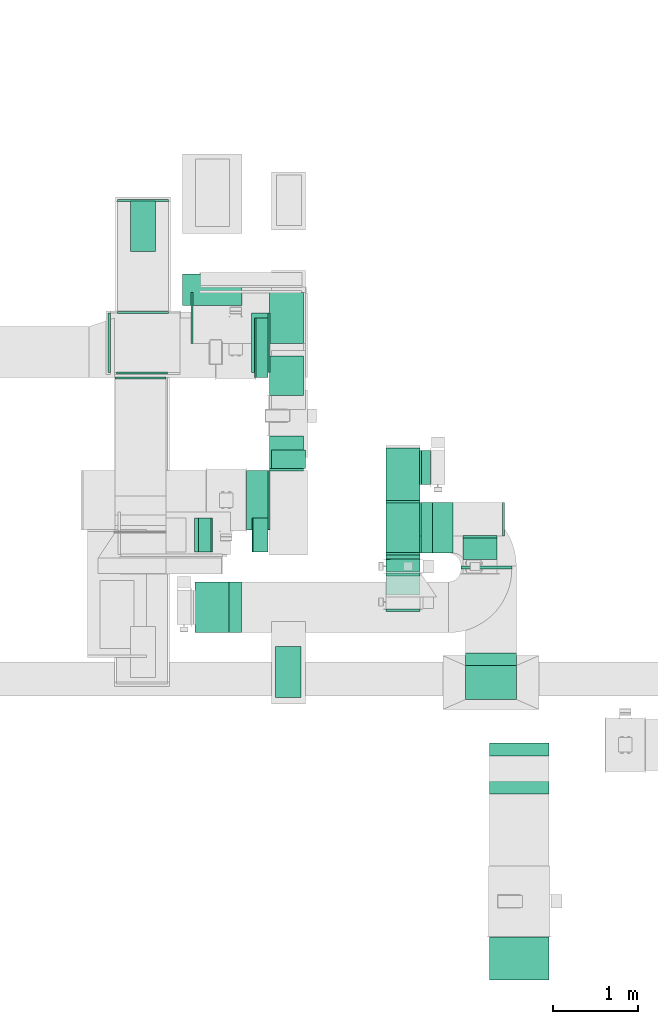
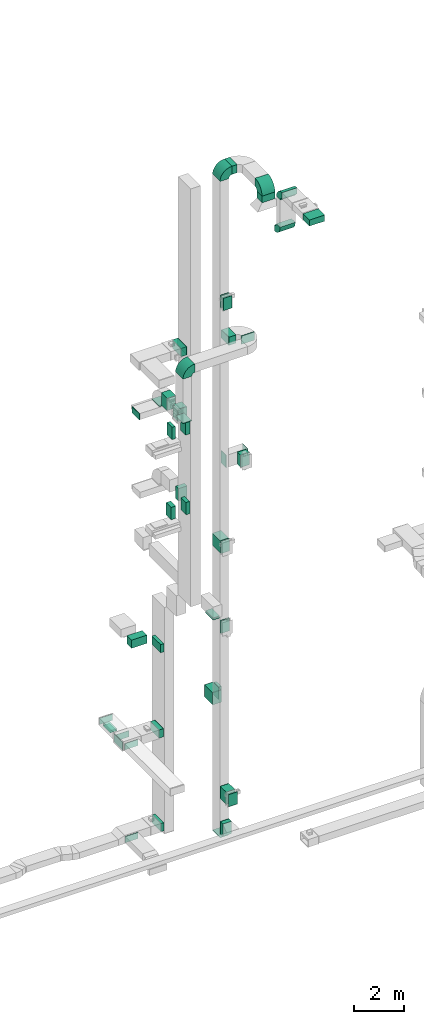
# One storey, part 12 of 25: 32 flow fittings, 28 flow segments, 1 flow terminal.
"""IFC2X3 building model written with IfcOpenShell, lengths in millimetres."""

from ifc_helpers import new_model, entity, si_unit, converted_unit, derived_unit, direction, frame, frame_2d, origin, origin_2d_with_axis, place, context, subcontext, project, spatial, polyline, circle_curve, parameter, trimmed, segment, composite_curve, rectangle, outline, extrude, source, transform, mapped, material, type_object, type_shapes, element, save


model = new_model("IFC2X3")

# Units and contexts
model_context = context("Model", 3, precision=0.01, world=origin(), true_north=direction((6.12303176911189e-17, 1.0)))
body_context = subcontext(model_context, "Body", "Model", "MODEL_VIEW")
ifc_project = project(units=[si_unit("LENGTHUNIT", "METRE", prefix="MILLI"), si_unit("AREAUNIT", "SQUARE_METRE"), si_unit("VOLUMEUNIT", "CUBIC_METRE"), converted_unit("PLANEANGLEUNIT", "DEGREE", entity("IfcRatioMeasure", 0.0174532925199433), si_unit("PLANEANGLEUNIT", "RADIAN"), dimensions=[0, 0, 0, 0, 0, 0, 0]), si_unit("MASSUNIT", "GRAM", prefix="KILO"), derived_unit("MASSDENSITYUNIT", [(si_unit("MASSUNIT", "GRAM", prefix="KILO"), 1), (si_unit("LENGTHUNIT", "METRE"), -3)]), derived_unit("MOMENTOFINERTIAUNIT", [(si_unit("LENGTHUNIT", "METRE"), 4)]), si_unit("TIMEUNIT", "SECOND"), si_unit("FREQUENCYUNIT", "HERTZ"), si_unit("THERMODYNAMICTEMPERATUREUNIT", "DEGREE_CELSIUS"), derived_unit("THERMALTRANSMITTANCEUNIT", [(si_unit("MASSUNIT", "GRAM", prefix="KILO"), 1), (si_unit("THERMODYNAMICTEMPERATUREUNIT", "KELVIN"), -1), (si_unit("TIMEUNIT", "SECOND"), -3)]), derived_unit("VOLUMETRICFLOWRATEUNIT", [(si_unit("LENGTHUNIT", "METRE"), 3), (si_unit("TIMEUNIT", "SECOND"), -1)]), derived_unit("MASSFLOWRATEUNIT", [(si_unit("MASSUNIT", "GRAM", prefix="KILO"), 1), (si_unit("TIMEUNIT", "SECOND"), -1)]), derived_unit("ROTATIONALFREQUENCYUNIT", [(si_unit("TIMEUNIT", "SECOND"), -1)]), si_unit("ELECTRICCURRENTUNIT", "AMPERE"), si_unit("ELECTRICVOLTAGEUNIT", "VOLT"), si_unit("POWERUNIT", "WATT"), si_unit("FORCEUNIT", "NEWTON", prefix="KILO"), si_unit("ILLUMINANCEUNIT", "LUX"), si_unit("LUMINOUSFLUXUNIT", "LUMEN"), si_unit("LUMINOUSINTENSITYUNIT", "CANDELA"), derived_unit("USERDEFINED", [(si_unit("MASSUNIT", "GRAM", prefix="KILO"), -1), (si_unit("LENGTHUNIT", "METRE"), -2), (si_unit("TIMEUNIT", "SECOND"), 3), (si_unit("LUMINOUSFLUXUNIT", "LUMEN"), 1)]), derived_unit("LINEARVELOCITYUNIT", [(si_unit("LENGTHUNIT", "METRE"), 1), (si_unit("TIMEUNIT", "SECOND"), -1)]), si_unit("PRESSUREUNIT", "PASCAL"), derived_unit("USERDEFINED", [(si_unit("LENGTHUNIT", "METRE"), -2), (si_unit("MASSUNIT", "GRAM", prefix="KILO"), 1), (si_unit("TIMEUNIT", "SECOND"), -2)]), derived_unit("LINEARFORCEUNIT", [(si_unit("MASSUNIT", "GRAM", prefix="KILO"), 1), (si_unit("LENGTHUNIT", "METRE"), 1), (si_unit("TIMEUNIT", "SECOND"), -2), (si_unit("LENGTHUNIT", "METRE"), -1)]), derived_unit("PLANARFORCEUNIT", [(si_unit("MASSUNIT", "GRAM", prefix="KILO"), 1), (si_unit("LENGTHUNIT", "METRE"), 1), (si_unit("TIMEUNIT", "SECOND"), -2), (si_unit("LENGTHUNIT", "METRE"), -2)])], contexts=[model_context])

# Site, building, storey
site_placement = place(None, origin())
site = spatial("IfcSite", under=ifc_project, at=site_placement, CompositionType="ELEMENT")
building_placement = place(site_placement, origin())
building = spatial("IfcBuilding", under=site, at=building_placement, CompositionType="ELEMENT")
storey_placement = place(building_placement, origin())
storey = spatial("IfcBuildingStorey", under=building, at=storey_placement, CompositionType="ELEMENT", Elevation=0.0)

# Flow segments
duct_segment_type = type_object("IfcDuctSegmentType", PredefinedType="NOTDEFINED")
flow_segment_1_placement = place(storey_placement, frame((30023.91, 10939.62, 22300.0)))
element("IfcFlowSegment", 1, at=flow_segment_1_placement, inside=storey, type_object=duct_segment_type, context=body_context, shape_type="SweptSolid", body=[
    extrude(rectangle(XDim=251.096000000203, YDim=699.999999999999, at=origin_2d_with_axis()), frame((125.55, 350.0, 0.0)), (0.0, 0.0, 1.0), 399.999999999996),
])
flow_segment_2_placement = place(storey_placement, frame((29456.92, 10677.38, 18600.0)))
element("IfcFlowSegment", 2, at=flow_segment_2_placement, inside=storey, type_object=duct_segment_type, context=body_context, shape_type="SweptSolid", body=[
    extrude(rectangle(XDim=150.000000000005, YDim=400.0, at=origin_2d_with_axis()), frame((75.0, 200.0, 0.0), z_axis=(0.0, 0.0, 1.0), x_axis=(-1.0, 0.0, 0.0)), (0.0, 0.0, 1.0), 599.999999999998),
])
flow_segment_3_placement = place(storey_placement, frame((30086.92, 10677.38, 18600.0)))
element("IfcFlowSegment", 3, at=flow_segment_3_placement, inside=storey, type_object=duct_segment_type, context=body_context, shape_type="SweptSolid", body=[
    extrude(rectangle(XDim=188.084749285835, YDim=400.0, at=origin_2d_with_axis()), frame((94.04, 200.0, 0.0), z_axis=(0.0, 0.0, 1.0), x_axis=(-1.0, 0.0, 0.0)), (0.0, 0.0, 1.0), 600.000000000002),
])
flow_segment_4_placement = place(storey_placement, frame((30101.92, 10677.38, 14700.0)))
element("IfcFlowSegment", 4, at=flow_segment_4_placement, inside=storey, type_object=duct_segment_type, context=body_context, shape_type="SweptSolid", body=[
    extrude(rectangle(XDim=173.084749285813, YDim=400.0, at=origin_2d_with_axis()), frame((86.54, 200.0, 0.0), z_axis=(0.0, 0.0, 1.0), x_axis=(-1.0, 0.0, 0.0)), (0.0, 0.0, 1.0), 600.000000000002),
])
flow_segment_5_placement = place(storey_placement, frame((30365.0, 8960.33, 10500.0)))
element("IfcFlowSegment", 5, at=flow_segment_5_placement, inside=storey, type_object=duct_segment_type, context=body_context, shape_type="SweptSolid", body=[
    extrude(rectangle(XDim=300.000000000001, YDim=600.0, at=origin_2d_with_axis()), frame((150.0, 300.0, 0.0)), (0.0, 0.0, 1.0), 79.9999999999688),
])
flow_segment_6_placement = place(storey_placement, frame((30120.05, 12737.72, 6700.0)))
element("IfcFlowSegment", 6, at=flow_segment_6_placement, inside=storey, type_object=duct_segment_type, context=body_context, shape_type="SweptSolid", body=[
    extrude(rectangle(XDim=154.950539610895, YDim=699.999999999999, at=origin_2d_with_axis()), frame((77.48, 350.0, 0.0), z_axis=(0.0, 0.0, 1.0), x_axis=(-1.0, 0.0, 0.0)), (0.0, 0.0, 1.0), 400.0),
])
flow_segment_7_placement = place(storey_placement, frame((30320.0, 11661.58, 14700.0)))
element("IfcFlowSegment", 7, at=flow_segment_7_placement, inside=storey, type_object=duct_segment_type, context=body_context, shape_type="SweptSolid", body=[
    extrude(rectangle(XDim=221.175631375204, YDim=400.0, at=origin_2d_with_axis()), frame((200.0, 110.59, 0.0), z_axis=(0.0, 0.0, 1.0), x_axis=(0.0, 1.0, 0.0)), (0.0, 0.0, 1.0), 600.000000000002),
])
flow_segment_8_placement = place(storey_placement, frame((30295.0, 11661.84, 18600.0)))
element("IfcFlowSegment", 8, at=flow_segment_8_placement, inside=storey, type_object=duct_segment_type, context=body_context, shape_type="SweptSolid", body=[
    extrude(rectangle(XDim=384.504473210767, YDim=400.0, at=origin_2d_with_axis()), frame((200.0, 192.25, 0.0), z_axis=(0.0, 0.0, 1.0), x_axis=(0.0, -1.0, 0.0)), (0.0, 0.0, 1.0), 600.000000000002),
])
flow_segment_9_placement = place(storey_placement, frame((29270.05, 13587.72, 6700.0)))
element("IfcFlowSegment", 9, at=flow_segment_9_placement, inside=storey, type_object=duct_segment_type, context=body_context, shape_type="SweptSolid", body=[
    extrude(rectangle(XDim=371.982987517842, YDim=700.000000000001, at=origin_2d_with_axis()), frame((350.0, 185.99, 0.0), z_axis=(0.0, 0.0, 1.0), x_axis=(0.0, 1.0, 0.0)), (0.0, 0.0, 1.0), 400.0),
])
flow_segment_10_placement = place(storey_placement, frame((28651.05, 14225.01, 2400.0)))
element("IfcFlowSegment", 10, at=flow_segment_10_placement, inside=storey, type_object=duct_segment_type, context=body_context, shape_type="SweptSolid", body=[
    extrude(rectangle(XDim=599.999999999998, YDim=300.000000000001, at=origin_2d_with_axis()), frame((150.0, 300.0, 0.0), z_axis=(0.0, 0.0, 1.0), x_axis=(0.0, 1.0, 0.0)), (0.0, 0.0, 1.0), 79.9999999999699),
])
flow_segment_11_placement = place(storey_placement, frame((30080.11, 12797.72, 2500.0)))
element("IfcFlowSegment", 11, at=flow_segment_11_placement, inside=storey, type_object=duct_segment_type, context=body_context, shape_type="SweptSolid", body=[
    extrude(rectangle(XDim=194.892683525825, YDim=699.999999999999, at=origin_2d_with_axis()), frame((97.45, 350.0, 0.0), z_axis=(0.0, 0.0, 1.0), x_axis=(-1.0, 0.0, 0.0)), (0.0, 0.0, 1.0), 400.0),
])
flow_segment_12_placement = place(storey_placement, frame((30135.54, 12739.72, -2050.0)))
element("IfcFlowSegment", 12, at=flow_segment_12_placement, inside=storey, type_object=duct_segment_type, context=body_context, shape_type="SweptSolid", body=[
    extrude(rectangle(XDim=139.457065215677, YDim=699.999999999999, at=origin_2d_with_axis()), frame((69.73, 350.0, 0.0)), (0.0, 0.0, 1.0), 400.0),
])
flow_segment_13_placement = place(storey_placement, frame((32219.87, 10665.1, 30605.49)))
element("IfcFlowSegment", 13, at=flow_segment_13_placement, inside=storey, type_object=duct_segment_type, context=body_context, shape_type="SweptSolid", body=[
    extrude(rectangle(XDim=239.145151963278, YDim=600.0, at=origin_2d_with_axis()), frame((119.57, 300.0, 0.0)), (0.0, 0.0, 1.0), 399.999999999996),
])
flow_segment_14_placement = place(storey_placement, frame((31669.87, 10592.36, 24300.0)))
element("IfcFlowSegment", 14, at=flow_segment_14_placement, inside=storey, type_object=duct_segment_type, context=body_context, shape_type="SweptSolid", body=[
    extrude(rectangle(XDim=52.6715277765037, YDim=400.000000000002, at=origin_2d_with_axis()), frame((200.01, 26.4, 0.0), z_axis=(0.0, 0.0, 1.0), x_axis=(0.000311966680507818, -0.999999951338394, 0.0)), (0.0, 0.0, 1.0), 600.000000000002),
])
flow_segment_15_placement = place(storey_placement, frame((32089.87, 10665.1, 22300.0)))
element("IfcFlowSegment", 15, at=flow_segment_15_placement, inside=storey, type_object=duct_segment_type, context=body_context, shape_type="SweptSolid", body=[
    extrude(rectangle(XDim=315.331551336668, YDim=600.0, at=origin_2d_with_axis()), frame((157.67, 300.0, 0.0), z_axis=(0.0, 0.0, 1.0), x_axis=(-1.0, 0.0, 0.0)), (0.0, 0.0, 1.0), 399.999999999996),
])
flow_segment_16_placement = place(storey_placement, frame((32555.21, 10474.94, 22300.0)))
element("IfcFlowSegment", 16, at=flow_segment_16_placement, inside=storey, type_object=duct_segment_type, context=body_context, shape_type="SweptSolid", body=[
    extrude(rectangle(XDim=40.1525169212813, YDim=600.000000000002, at=origin_2d_with_axis()), frame((300.0, 20.08, 0.0), z_axis=(0.0, 0.0, 1.0), x_axis=(0.0, 1.0, 0.0)), (0.0, 0.0, 1.0), 399.999999999996),
])
flow_segment_17_placement = place(storey_placement, frame((32581.61, 10592.04, 16200.0)))
element("IfcFlowSegment", 17, at=flow_segment_17_placement, inside=storey, type_object=duct_segment_type, context=body_context, shape_type="SweptSolid", body=[
    extrude(rectangle(XDim=253.039939388961, YDim=399.999999999998, at=origin_2d_with_axis()), frame((200.01, 126.53, 0.0), z_axis=(0.0, 0.0, 1.0), x_axis=(6.49374233861676e-05, -0.999999997891566, 0.0)), (0.0, 0.0, 1.0), 599.999999999998),
])
flow_segment_18_placement = place(storey_placement, frame((31669.88, 10594.95, 12300.0)))
element("IfcFlowSegment", 18, at=flow_segment_18_placement, inside=storey, type_object=duct_segment_type, context=body_context, shape_type="SweptSolid", body=[
    extrude(rectangle(XDim=50.0956791701616, YDim=400.000000000001, at=origin_2d_with_axis()), frame((200.01, 25.09, 0.0), z_axis=(0.0, 0.0, 1.0), x_axis=(0.000234419037960343, -0.999999972523857, 0.0)), (0.0, 0.0, 1.0), 599.999999999998),
])
flow_segment_19_placement = place(storey_placement, frame((31669.87, 11285.1, 4500.0)))
element("IfcFlowSegment", 19, at=flow_segment_19_placement, inside=storey, type_object=duct_segment_type, context=body_context, shape_type="SweptSolid", body=[
    extrude(rectangle(XDim=623.157125447534, YDim=400.0, at=origin_2d_with_axis()), frame((200.0, 311.58, 0.0), z_axis=(0.0, 0.0, 1.0), x_axis=(0.0, 1.0, 0.0)), (0.0, 0.0, 1.0), 600.0),
])
flow_segment_20_placement = place(storey_placement, frame((32089.84, 11475.22, 4500.0)))
element("IfcFlowSegment", 20, at=flow_segment_20_placement, inside=storey, type_object=duct_segment_type, context=body_context, shape_type="SweptSolid", body=[
    extrude(rectangle(XDim=108.106004089515, YDim=400.0, at=origin_2d_with_axis()), frame((54.08, 200.01, 0.0), z_axis=(0.0, 0.0, 1.0), x_axis=(0.999999988448493, 0.00015199675370579, 0.0)), (0.0, 0.0, 1.0), 600.000000000001),
])
flow_segment_21_placement = place(storey_placement, frame((31669.87, 10172.23, 300.0)))
element("IfcFlowSegment", 21, at=flow_segment_21_placement, inside=storey, type_object=duct_segment_type, context=body_context, shape_type="SweptSolid", body=[
    extrude(rectangle(XDim=471.797025863042, YDim=400.000000000001, at=origin_2d_with_axis()), frame((200.01, 235.91, 0.0), z_axis=(0.0, 0.0, 1.0), x_axis=(3.48280314986155e-05, -1.0, 0.0)), (0.0, 0.0, 1.0), 600.0),
])
flow_segment_22_placement = place(storey_placement, frame((31669.87, 10445.0, -1425.0)))
element("IfcFlowSegment", 22, at=flow_segment_22_placement, inside=storey, type_object=duct_segment_type, context=body_context, shape_type="SweptSolid", body=[
    extrude(rectangle(XDim=200.095053159419, YDim=400.0, at=origin_2d_with_axis()), frame((200.0, 100.05, 0.0), z_axis=(0.0, 0.0, 1.0), x_axis=(0.0, 1.0, 0.0)), (0.0, 0.0, 1.0), 600.0),
])
flow_segment_23_placement = place(storey_placement, frame((32894.02, 5625.0, 30900.0)))
element("IfcFlowSegment", 23, at=flow_segment_23_placement, inside=storey, type_object=duct_segment_type, context=body_context, shape_type="SweptSolid", body=[
    extrude(rectangle(XDim=507.958451099597, YDim=700.000000000001, at=origin_2d_with_axis()), frame((350.0, 253.98, 0.0), z_axis=(0.0, 0.0, 1.0), x_axis=(0.0, -1.0, 0.0)), (0.0, 0.0, 1.0), 300.000000000001),
])
flow_segment_24_placement = place(storey_placement, frame((32609.02, 8936.91, 30130.0)))
element("IfcFlowSegment", 24, at=flow_segment_24_placement, inside=storey, type_object=duct_segment_type, context=body_context, shape_type="SweptSolid", body=[
    extrude(rectangle(XDim=600.000000000002, YDim=400.0, at=origin_2d_with_axis()), frame((300.0, 200.0, 0.0)), (0.0, 0.0, 1.0), 325.490894035817),
])
flow_segment_25_placement = place(storey_placement, frame((31669.88, 10595.33, 8400.0)))
element("IfcFlowSegment", 25, at=flow_segment_25_placement, inside=storey, type_object=duct_segment_type, context=body_context, shape_type="SweptSolid", body=[
    extrude(rectangle(XDim=49.715642394297, YDim=400.000000000001, at=origin_2d_with_axis()), frame((200.01, 24.9, 0.0), z_axis=(0.0, 0.0, 1.0), x_axis=(-0.00023569691278059, 0.999999972223482, 0.0)), (0.0, 0.0, 1.0), 600.0),
])
flow_segment_26_placement = place(storey_placement, frame((29411.92, 10677.38, 14700.0)))
element("IfcFlowSegment", 26, at=flow_segment_26_placement, inside=storey, type_object=duct_segment_type, context=body_context, shape_type="SweptSolid", body=[
    extrude(rectangle(XDim=210.000000000009, YDim=400.0, at=origin_2d_with_axis()), frame((105.0, 200.0, 0.0), z_axis=(0.0, 0.0, 1.0), x_axis=(-1.0, 0.0, 0.0)), (0.0, 0.0, 1.0), 600.000000000002),
])
flow_segment_27_placement = place(storey_placement, frame((30295.0, 12526.34, 18600.0)))
element("IfcFlowSegment", 27, at=flow_segment_27_placement, inside=storey, type_object=duct_segment_type, context=body_context, shape_type="SweptSolid", body=[
    extrude(rectangle(XDim=466.041082953118, YDim=400.0, at=origin_2d_with_axis()), frame((200.0, 233.02, 0.0), z_axis=(0.0, 0.0, 1.0), x_axis=(0.0, 1.0, 0.0)), (0.0, 0.0, 1.0), 600.000000000002),
])
flow_segment_28_placement = place(storey_placement, frame((30295.0, 13142.38, 18420.0)))
element("IfcFlowSegment", 28, at=flow_segment_28_placement, inside=storey, type_object=duct_segment_type, context=body_context, shape_type="SweptSolid", body=[
    extrude(rectangle(XDim=400.000000000004, YDim=600.0, at=origin_2d_with_axis()), frame((200.0, 300.0, 0.0)), (0.0, 0.0, 1.0), 29.9999999999975),
])

# Flow fittings
ifc_material_1 = material()
duct_fitting_type_1 = type_object("IfcDuctFittingType", PredefinedType="NOTDEFINED", material=ifc_material_1)
shared_shape_1 = source(origin(), body_context, "Body", "SweptSolid", [
    extrude(rectangle(XDim=24.9999999999999, YDim=700.0, at=origin_2d_with_axis()), frame((12.5, 0.0, -200.0)), (0.0, 0.0, 1.0), 400.0),
])
type_shapes(duct_fitting_type_1, [shared_shape_1])
flow_fitting_1_placement = place(storey_placement, frame((28415.0, 13147.72, 2700.0), z_axis=(0.0, 0.0, 1.0), x_axis=(-1.0, 0.0, 0.0)))
element("IfcFlowFitting", 29, at=flow_fitting_1_placement, inside=storey, type_object=duct_fitting_type_1, material=ifc_material_1, context=body_context, shape_type="MappedRepresentation", body=[
    mapped(shared_shape_1, transform((0.0, 0.0, 0.0), scale=1.0)),
])
duct_fitting_type_2 = type_object("IfcDuctFittingType", PredefinedType="NOTDEFINED", material=ifc_material_1)
shared_shape_2 = source(origin(), body_context, "Body", "SweptSolid", [
    extrude(rectangle(XDim=26.0960000000006, YDim=400.0, at=origin_2d_with_axis()), frame((6.95, 0.0, -350.0)), (0.0, 0.0, 1.0), 700.0),
])
type_shapes(duct_fitting_type_2, [shared_shape_2])
for number, where, z_axis, x_axis in (
    (30, (30295.0, 11292.62, 22500.0), (0.0, 1.0, 0.0), (-1.0, 0.0, 0.0)),
    (31, (30295.0, 13147.72, 2700.0), (0.0, 1.0, 0.0), (-1.0, 0.0, 0.0)),
    (32, (30295.0, 11289.62, 22500.0), (0.0, 1.0, 0.0), (-1.0, 0.0, 0.0)),
):
    element("IfcFlowFitting", number, at=place(storey_placement, frame(where, z_axis=z_axis, x_axis=x_axis)), inside=storey, type_object=duct_fitting_type_2, material=ifc_material_1, context=body_context, shape_type="MappedRepresentation", body=[
        mapped(shared_shape_2, transform((0.0, 0.0, 0.0), scale=1.0)),
    ])
duct_fitting_type_3 = type_object("IfcDuctFittingType", PredefinedType="NOTDEFINED", material=ifc_material_1)
shared_shape_3 = source(origin(), body_context, "Body", "SweptSolid", [
    extrude(rectangle(XDim=26.0960000000009, YDim=600.0, at=origin_2d_with_axis()), frame((6.95, 0.0, -200.0)), (0.0, 0.0, 1.0), 400.0),
])
type_shapes(duct_fitting_type_3, [shared_shape_3])
for number, where, z_axis, x_axis in (
    (33, (31869.87, 10665.1, 24600.0), (-1.0, 0.0, 0.0), (0.0, -1.0, 0.0)),
    (34, (32069.87, 11065.1, 16500.0), (0.0, -1.0, 0.0), (1.0, 0.0, 0.0)),
    (35, (31869.87, 11265.1, 4800.0), (1.0, 0.0, 0.0), (0.0, 1.0, 0.0)),
):
    element("IfcFlowFitting", number, at=place(storey_placement, frame(where, z_axis=z_axis, x_axis=x_axis)), inside=storey, type_object=duct_fitting_type_3, material=ifc_material_1, context=body_context, shape_type="MappedRepresentation", body=[
        mapped(shared_shape_3, transform((0.0, 0.0, 0.0), scale=1.0)),
    ])
duct_fitting_type_4 = type_object("IfcDuctFittingType", PredefinedType="NOTDEFINED", material=ifc_material_1)
shared_shape_4 = source(origin(), body_context, "Body", "SweptSolid", [
    extrude(rectangle(XDim=24.9999999999999, YDim=400.0, at=origin_2d_with_axis()), frame((12.5, 0.0, -300.0)), (0.0, 0.0, 1.0), 600.0),
])
type_shapes(duct_fitting_type_4, [shared_shape_4])
flow_fitting_2_placement = place(storey_placement, frame((31869.87, 10422.42, 24600.0), z_axis=(0.0, 0.0, 1.0), x_axis=(0.0, -1.0, 0.0)))
element("IfcFlowFitting", 36, at=flow_fitting_2_placement, inside=storey, type_object=duct_fitting_type_4, material=ifc_material_1, context=body_context, shape_type="MappedRepresentation", body=[
    mapped(shared_shape_4, transform((0.0, 0.0, 0.0), scale=1.0)),
])
flow_fitting_3_placement = place(storey_placement, frame((33044.03, 11065.1, 16500.0)))
element("IfcFlowFitting", 37, at=flow_fitting_3_placement, inside=storey, type_object=duct_fitting_type_4, material=ifc_material_1, context=body_context, shape_type="MappedRepresentation", body=[
    mapped(shared_shape_4, transform((0.0, 0.0, 0.0), scale=1.0)),
])
flow_fitting_4_placement = place(storey_placement, frame((31869.87, 10002.24, 600.0), z_axis=(0.0, 0.0, 1.0), x_axis=(0.0, -1.0, 0.0)))
element("IfcFlowFitting", 38, at=flow_fitting_4_placement, inside=storey, type_object=duct_fitting_type_4, material=ifc_material_1, context=body_context, shape_type="MappedRepresentation", body=[
    mapped(shared_shape_4, transform((0.0, 0.0, 0.0), scale=1.0)),
])
duct_fitting_type_5 = type_object("IfcDuctFittingType", PredefinedType="NOTDEFINED", material=ifc_material_1)
shared_shape_5 = source(origin(), body_context, "Body", "SweptSolid", [
    extrude(rectangle(XDim=26.0960000000291, YDim=600.0, at=origin_2d_with_axis()), frame((6.95, 0.0, -150.0)), (0.0, 0.0, 1.0), 300.0),
])
type_shapes(duct_fitting_type_5, [shared_shape_5])
for number, where, z_axis, x_axis in (
    (39, (28801.05, 13497.72, 2650.0), (0.0, 0.0, -1.0), (0.0, 1.0, 0.0)),
    (40, (30515.0, 9260.33, 10600.0), (1.0, 0.0, 0.0), (0.0, 0.0, -1.0)),
):
    element("IfcFlowFitting", number, at=place(storey_placement, frame(where, z_axis=z_axis, x_axis=x_axis)), inside=storey, type_object=duct_fitting_type_5, material=ifc_material_1, context=body_context, shape_type="MappedRepresentation", body=[
        mapped(shared_shape_5, transform((0.0, 0.0, 0.0), scale=1.0)),
    ])
duct_fitting_type_6 = type_object("IfcDuctFittingType", PredefinedType="NOTDEFINED", material=ifc_material_1)
shared_shape_6 = source(origin(), body_context, "Body", "SweptSolid", [
    extrude(rectangle(XDim=24.9999999999999, YDim=600.0, at=origin_2d_with_axis()), frame((12.5, 0.0, -150.0)), (0.0, 0.0, 1.0), 300.0),
])
type_shapes(duct_fitting_type_6, [shared_shape_6])
for number, where, z_axis, x_axis in (
    (41, (28801.05, 14817.24, 2650.0), (0.0, 0.0, 1.0), (0.0, 1.0, 0.0)),
    (42, (29393.94, 13442.38, 18250.0), (0.0, 0.0, 1.0), (-1.0, 0.0, 0.0)),
):
    element("IfcFlowFitting", number, at=place(storey_placement, frame(where, z_axis=z_axis, x_axis=x_axis)), inside=storey, type_object=duct_fitting_type_6, material=ifc_material_1, context=body_context, shape_type="MappedRepresentation", body=[
        mapped(shared_shape_6, transform((0.0, 0.0, 0.0), scale=1.0)),
    ])
duct_fitting_type_7 = type_object("IfcDuctFittingType", PredefinedType="NOTDEFINED", material=ifc_material_1)
shared_shape_7 = source(origin(), body_context, "Body", "SweptSolid", [
    extrude(rectangle(XDim=300.0, YDim=26.0960000000498, at=origin_2d_with_axis()), frame((6.95, 0.0, -300.0), z_axis=(0.0, 0.0, 1.0), x_axis=(0.0, -1.0, 0.0)), (0.0, 0.0, 1.0), 600.0),
])
type_shapes(duct_fitting_type_7, [shared_shape_7])
flow_fitting_5_placement = place(storey_placement, frame((28801.05, 14525.01, 2500.0), z_axis=(0.0, 1.0, 0.0), x_axis=(0.0, 0.0, -1.0)))
element("IfcFlowFitting", 43, at=flow_fitting_5_placement, inside=storey, type_object=duct_fitting_type_7, material=ifc_material_1, context=body_context, shape_type="MappedRepresentation", body=[
    mapped(shared_shape_7, transform((0.0, 0.0, 0.0), scale=1.0)),
])
duct_fitting_type_8 = type_object("IfcDuctFittingType", PredefinedType="NOTDEFINED", material=ifc_material_1)
shared_shape_8 = source(origin(), body_context, "Body", "SweptSolid", [
    extrude(rectangle(XDim=600.0, YDim=26.0960000000493, at=origin_2d_with_axis()), frame((6.95, 0.0, -150.0), z_axis=(0.0, 0.0, 1.0), x_axis=(0.0, -1.0, 0.0)), (0.0, 0.0, 1.0), 300.0),
])
type_shapes(duct_fitting_type_8, [shared_shape_8])
for number, where, z_axis, x_axis in (
    (44, (28789.1, 12797.72, 2650.0), (0.0, 0.0, -1.0), (0.0, -1.0, 0.0)),
    (45, (28769.95, 12739.72, -1850.0), (0.0, 0.0, -1.0), (0.0, -1.0, 0.0)),
):
    element("IfcFlowFitting", number, at=place(storey_placement, frame(where, z_axis=z_axis, x_axis=x_axis)), inside=storey, type_object=duct_fitting_type_8, material=ifc_material_1, context=body_context, shape_type="MappedRepresentation", body=[
        mapped(shared_shape_8, transform((0.0, 0.0, 0.0), scale=1.0)),
    ])

# Flow terminal
ifc_material_2 = material()
air_terminal_type = type_object("IfcAirTerminalType", PredefinedType="NOTDEFINED", material=ifc_material_2)
shared_shape_9 = source(origin(), body_context, "Body", "SweptSolid", [
    extrude(rectangle(XDim=4.0, YDim=599.999999999999, at=origin_2d_with_axis()), frame((0.0, -2.0, -150.0), z_axis=(0.0, 0.0, 1.0), x_axis=(0.0, 1.0, 0.0)), (0.0, 0.0, 1.0), 300.000000000005),
])
type_shapes(air_terminal_type, [shared_shape_9])
flow_terminal_placement = place(storey_placement, frame((28801.05, 14525.01, 2400.0), z_axis=(-1.0, 0.0, 0.0), x_axis=(0.0, -1.0, 0.0)))
element("IfcFlowTerminal", 46, at=flow_terminal_placement, inside=storey, type_object=air_terminal_type, material=ifc_material_2, context=body_context, shape_type="MappedRepresentation", body=[
    mapped(shared_shape_9, transform((0.0, 0.0, 0.0), scale=1.0)),
])

# Flow fittings
duct_fitting_type_9 = type_object("IfcDuctFittingType", PredefinedType="NOTDEFINED", material=ifc_material_1)
shared_shape_10 = source(origin(), body_context, "Body", "SweptSolid", [
    extrude(rectangle(XDim=24.9999999999999, YDim=600.0, at=origin_2d_with_axis()), frame((12.5, 0.0, -200.0)), (0.0, 0.0, 1.0), 400.0),
])
type_shapes(duct_fitting_type_9, [shared_shape_10])
for number, where, z_axis, x_axis in (
    (47, (29615.56, 10024.94, 20000.0), (1.0, 0.0, 0.0), (0.0, 0.0, -1.0)),
    (48, (31869.87, 10965.1, -1605.0), (1.0, 0.0, 0.0), (0.0, 0.0, -1.0)),
):
    element("IfcFlowFitting", number, at=place(storey_placement, frame(where, z_axis=z_axis, x_axis=x_axis)), inside=storey, type_object=duct_fitting_type_9, material=ifc_material_1, context=body_context, shape_type="MappedRepresentation", body=[
        mapped(shared_shape_10, transform((0.0, 0.0, 0.0), scale=1.0)),
    ])
duct_fitting_type_10 = type_object("IfcDuctFittingType", PredefinedType="NOTDEFINED", material=ifc_material_1)
shared_shape_11 = source(origin(), body_context, "Body", "SweptSolid", [
    extrude(rectangle(XDim=600.0, YDim=26.096, at=origin_2d_with_axis()), frame((6.95, 0.0, -200.0), z_axis=(0.0, 0.0, 1.0), x_axis=(0.0, -1.0, 0.0)), (0.0, 0.0, 1.0), 400.0),
])
type_shapes(duct_fitting_type_10, [shared_shape_11])
for number, where, z_axis, x_axis in (
    (49, (31869.87, 10665.1, 8700.0), (-1.0, 0.0, 0.0), (0.0, -1.0, 0.0)),
    (50, (31869.87, 10665.1, -1125.0), (-1.0, 0.0, 0.0), (0.0, -1.0, 0.0)),
):
    element("IfcFlowFitting", number, at=place(storey_placement, frame(where, z_axis=z_axis, x_axis=x_axis)), inside=storey, type_object=duct_fitting_type_10, material=ifc_material_1, context=body_context, shape_type="MappedRepresentation", body=[
        mapped(shared_shape_11, transform((0.0, 0.0, 0.0), scale=1.0)),
    ])
duct_fitting_type_11 = type_object("IfcDuctFittingType", PredefinedType="NOTDEFINED", material=ifc_material_1)
shared_shape_12 = source(origin(), body_context, "Body", "SweptSolid", [
    extrude(rectangle(XDim=26.0960000000093, YDim=400.0, at=origin_2d_with_axis()), frame((6.95, 0.0, -300.0)), (0.0, 0.0, 1.0), 600.0),
])
type_shapes(duct_fitting_type_11, [shared_shape_12])
for number, where, z_axis, x_axis in (
    (51, (32069.87, 10965.1, 22500.0), (0.0, -1.0, 0.0), (1.0, 0.0, 0.0)),
    (52, (32781.61, 10865.1, 16500.0), (0.0, 0.0, -1.0), (0.0, -1.0, 0.0)),
    (53, (32069.87, 11675.22, 4800.0), (0.0, 0.0, -1.0), (1.0, 0.0, 0.0)),
):
    element("IfcFlowFitting", number, at=place(storey_placement, frame(where, z_axis=z_axis, x_axis=x_axis)), inside=storey, type_object=duct_fitting_type_11, material=ifc_material_1, context=body_context, shape_type="MappedRepresentation", body=[
        mapped(shared_shape_12, transform((0.0, 0.0, 0.0), scale=1.0)),
    ])
duct_fitting_type_12 = type_object("IfcDuctFittingType", PredefinedType="NOTDEFINED", material=ifc_material_1)
shared_shape_13 = source(origin(), body_context, "Body", "SweptSolid", [
    extrude(rectangle(XDim=28.2143610964482, YDim=600.0, at=origin_2d_with_axis()), frame((6.95, 0.0, -200.0)), (0.0, 0.0, 1.0), 400.0),
])
type_shapes(duct_fitting_type_12, [shared_shape_13])
flow_fitting_6_placement = place(storey_placement, frame((31869.87, 10665.1, 600.0), z_axis=(-1.0, 0.0, 0.0), x_axis=(0.0, -1.0, 0.0)))
element("IfcFlowFitting", 54, at=flow_fitting_6_placement, inside=storey, type_object=duct_fitting_type_12, material=ifc_material_1, context=body_context, shape_type="MappedRepresentation", body=[
    mapped(shared_shape_13, transform((0.0, 0.0, 0.0), scale=1.0)),
])
duct_fitting_type_13 = type_object("IfcDuctFittingType", PredefinedType="NOTDEFINED", material=ifc_material_1)
shared_shape_14 = source(origin(), body_context, "Body", "SweptSolid", [
    extrude(rectangle(XDim=600.0, YDim=626.049132676807, at=origin_2d_with_axis()), frame((-293.02, 0.0, -200.0), z_axis=(0.0, 0.0, 1.0), x_axis=(0.0, -1.0, 0.0)), (0.0, 0.0, 1.0), 400.0),
])
type_shapes(duct_fitting_type_13, [shared_shape_14])
flow_fitting_7_placement = place(storey_placement, frame((31869.87, 10665.1, 12600.0), z_axis=(-0.999999972523857, -0.000234419037975662, 0.0), x_axis=(0.000234419037975662, -0.999999972523857, 0.0)))
element("IfcFlowFitting", 55, at=flow_fitting_7_placement, inside=storey, type_object=duct_fitting_type_13, material=ifc_material_1, context=body_context, shape_type="MappedRepresentation", body=[
    mapped(shared_shape_14, transform((0.0, 0.0, 0.0), scale=1.0)),
])
duct_fitting_type_14 = type_object("IfcDuctFittingType", PredefinedType="NOTDEFINED", material=ifc_material_1)
shared_shape_15 = source(origin(), body_context, "Body", "SweptSolid", [
    extrude(rectangle(XDim=26.1514803164612, YDim=600.0, at=origin_2d_with_axis()), frame((6.98, 0.0, -200.0)), (0.0, 0.0, 1.0), 400.0),
])
type_shapes(duct_fitting_type_14, [shared_shape_15])
flow_fitting_8_placement = place(storey_placement, frame((30495.0, 11641.78, 18900.0), z_axis=(1.0, 0.0, 0.0), x_axis=(0.0, 1.0, 0.0)))
element("IfcFlowFitting", 56, at=flow_fitting_8_placement, inside=storey, type_object=duct_fitting_type_14, material=ifc_material_1, context=body_context, shape_type="MappedRepresentation", body=[
    mapped(shared_shape_15, transform((0.0, 0.0, 0.0), scale=1.0)),
])
duct_fitting_type_15 = type_object("IfcDuctFittingType", PredefinedType="NOTDEFINED", material=ifc_material_1)
shared_shape_16 = source(origin(), body_context, "Body", "SweptSolid", [
    extrude(outline(composite_curve([segment(polyline([(-375.0, -175.0), (25.0, -175.0)]), True, "CONTINUOUS"), segment(trimmed(circle_curve(frame_2d((175.0, -175.0), x_axis=(0.0, 1.0)), 150.0), [parameter(0.0)], [parameter(90.0000000000001)], True, "PARAMETER"), False, "CONTINUOUS"), segment(polyline([(175.0, -25.0), (175.0, 375.0)]), True, "CONTINUOUS"), segment(trimmed(circle_curve(frame_2d((175.0, -175.0), x_axis=(0.0, 1.0)), 550.0), [parameter(0.0)], [parameter(90.0)], True, "PARAMETER"), True, "CONTINUOUS")], self_intersect=False)), frame((-175.0, 175.0, -300.0), z_axis=(0.0, 0.0, 1.0), x_axis=(-1.0, 0.0, 0.0)), (0.0, 0.0, 1.0), 600.0),
])
type_shapes(duct_fitting_type_15, [shared_shape_16])
for number, where, z_axis, x_axis in (
    (57, (29615.56, 10024.94, 22500.0), (0.0, -1.0, 0.0), (-1.0, 0.0, 0.0)),
    (58, (31869.87, 10965.1, 30805.49), (0.0, -1.0, 0.0), (-1.0, 0.0, 0.0)),
    (59, (32909.02, 9136.91, 30805.49), (1.0, 0.0, 0.0), (0.0, -1.0, 0.0)),
):
    element("IfcFlowFitting", number, at=place(storey_placement, frame(where, z_axis=z_axis, x_axis=x_axis)), inside=storey, type_object=duct_fitting_type_15, material=ifc_material_1, context=body_context, shape_type="MappedRepresentation", body=[
        mapped(shared_shape_16, transform((0.0, 0.0, 0.0), scale=1.0)),
    ])
duct_fitting_type_16 = type_object("IfcDuctFittingType", PredefinedType="NOTDEFINED", material=ifc_material_1)
shared_shape_17 = source(origin(), body_context, "Body", "SweptSolid", [
    extrude(outline(composite_curve([segment(polyline([(-300.0, -150.0), (0.0, -150.0)]), True, "CONTINUOUS"), segment(trimmed(circle_curve(frame_2d((150.0, -150.0), x_axis=(0.0, 1.0)), 150.0), [parameter(0.0)], [parameter(90.0)], True, "PARAMETER"), False, "CONTINUOUS"), segment(polyline([(150.0, 0.0), (150.0, 300.0)]), True, "CONTINUOUS"), segment(trimmed(circle_curve(frame_2d((150.0, -150.0), x_axis=(0.0, 1.0)), 450.0), [parameter(0.0)], [parameter(90.0000000000001)], True, "PARAMETER"), True, "CONTINUOUS")], self_intersect=False)), frame((-150.0, 150.0, -350.0), z_axis=(0.0, 0.0, 1.0), x_axis=(-1.0, 0.0, 0.0)), (0.0, 0.0, 1.0), 700.0),
])
type_shapes(duct_fitting_type_16, [shared_shape_17])
for number, where, z_axis, x_axis in (
    (60, (33244.02, 8120.91, 31050.0), (1.0, 0.0, 0.0), (0.0, 0.0, 1.0)),
    (61, (33244.02, 8120.91, 29120.0), (1.0, 0.0, 0.0), (0.0, 0.0, -1.0)),
):
    element("IfcFlowFitting", number, at=place(storey_placement, frame(where, z_axis=z_axis, x_axis=x_axis)), inside=storey, type_object=duct_fitting_type_16, material=ifc_material_1, context=body_context, shape_type="MappedRepresentation", body=[
        mapped(shared_shape_17, transform((0.0, 0.0, 0.0), scale=1.0)),
    ])

save(model, "model.ifc")
